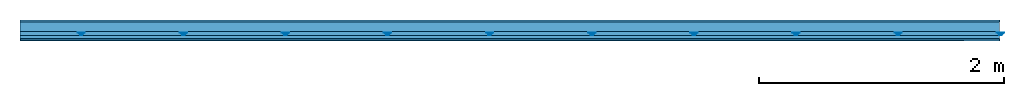
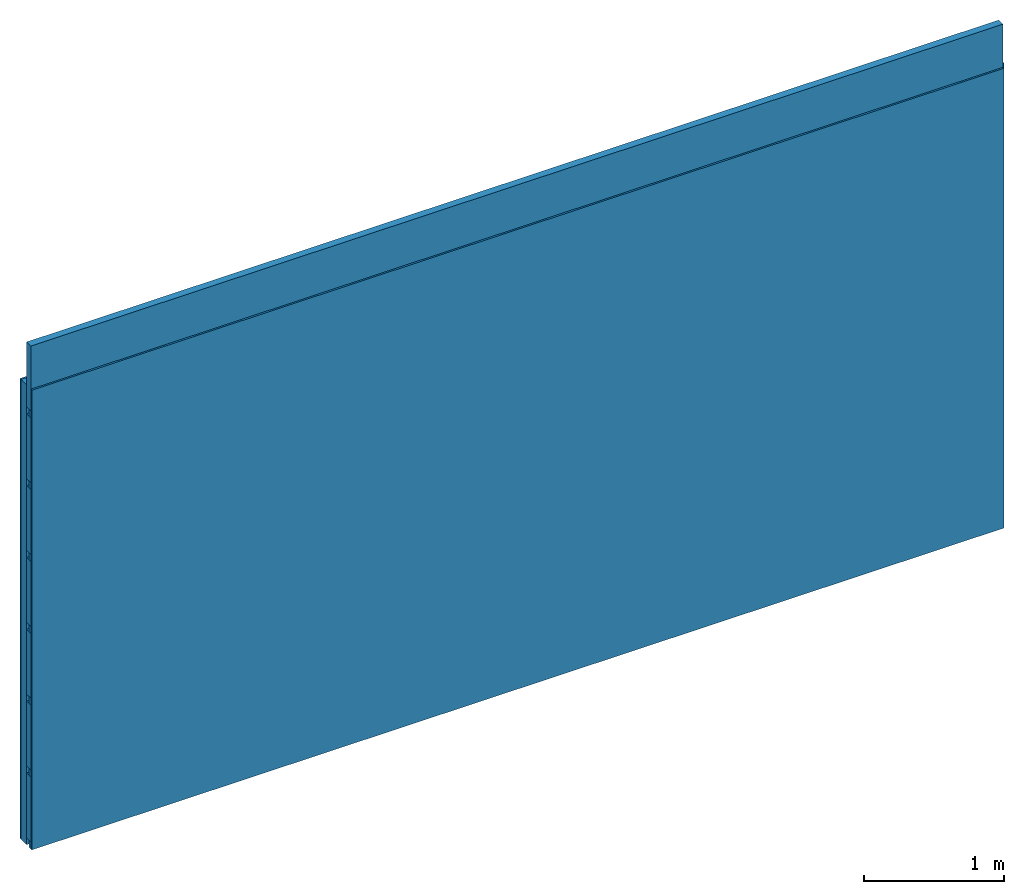
# One storey: 4 members, 2 plates, 1 element without a shape of its own.
"""IFC4 building model written with IfcOpenShell, lengths in metres."""

import ifcopenshell
import ifcopenshell.guid

model = None  # the IFC model being written
_history = None  # IfcOwnerHistory: only IFC2X3 demands one
_inside = {}  # id of a spatial element -> (the spatial element, [elements in it])
_under = {}  # id of a project, library or spatial element -> (it, [spatial elements below it])
_declared = {}  # id of a project -> (the project, [libraries it declares])
_typed = {}  # id of a type object -> (the type object, [elements of that type])
_made_of = {}  # id of a material, layer set ... -> (it, [elements and type objects made of it])


def new_model(schema):
    """Start an empty IFC model of exactly this schema.

    Asked for "IFC4X3", IfcOpenShell would pick the latest addendum, in which some entities
    have other attributes; the version numbers below select the first issue.
    IFC2X3 requires an IfcOwnerHistory on every rooted entity: one is made here for all.
    """
    global model, _history
    if schema == "IFC4X3":
        model = ifcopenshell.file(schema_version=(4, 3, 0, 0))
    else:
        model = ifcopenshell.file(schema=schema)
    _inside.clear()
    _under.clear()
    _declared.clear()
    _typed.clear()
    _made_of.clear()
    _history = None
    if model.schema == "IFC2X3":
        org = make("IfcOrganization", Name="unknown")
        user = make(
            "IfcPersonAndOrganization",
            ThePerson=make("IfcPerson", FamilyName="unknown"),
            TheOrganization=org,
        )
        app = make(
            "IfcApplication",
            ApplicationDeveloper=org,
            Version="unknown",
            ApplicationFullName="unknown",
            ApplicationIdentifier="unknown",
        )
        _history = make(
            "IfcOwnerHistory",
            OwningUser=user,
            OwningApplication=app,
            ChangeAction="ADDED",
            CreationDate=0,
        )
    return model


def make(cls, **values):
    """One entity of the class cls with the attributes given. An attribute that is None is left unset."""
    return model.create_entity(
        cls, **{name: value for name, value in values.items() if value is not None}
    )


def rooted(cls, **values):
    """An entity with a GlobalId (a new one), such as an element, a storey or a relation."""
    return make(cls, GlobalId=ifcopenshell.guid.new(), OwnerHistory=_history, **values)


def si_unit(unit_type, name, prefix=None):
    """IfcSIUnit, for example si_unit("LENGTHUNIT", "METRE", prefix="MILLI")."""
    return make("IfcSIUnit", UnitType=unit_type, Prefix=prefix, Name=name)


def derived_unit(unit_type, elements):
    """IfcDerivedUnit: a product of units, each with its exponent."""
    return make(
        "IfcDerivedUnit",
        Elements=[
            make("IfcDerivedUnitElement", Unit=unit, Exponent=power)
            for unit, power in elements
        ],
        UnitType=unit_type,
    )


def assignment(units):
    """IfcUnitAssignment: the units of a project."""
    return None if units is None else make("IfcUnitAssignment", Units=units)


def point(xyz):
    """IfcCartesianPoint."""
    return None if xyz is None else make("IfcCartesianPoint", Coordinates=xyz)


def direction(xyz):
    """IfcDirection."""
    return None if xyz is None else make("IfcDirection", DirectionRatios=xyz)


def frame(location, z_axis=None, x_axis=None):
    """IfcAxis2Placement3D, a coordinate frame: its origin and axes. An axis left out is left unset."""
    return make(
        "IfcAxis2Placement3D",
        Location=point(location),
        Axis=direction(z_axis),
        RefDirection=direction(x_axis),
    )


def frame_2d(location, x_axis=None):
    """IfcAxis2Placement2D, a coordinate frame in the plane: its origin and x axis."""
    return make(
        "IfcAxis2Placement2D", Location=point(location), RefDirection=direction(x_axis)
    )


def origin():
    """The frame at (0, 0, 0) with its axes left unset."""
    return frame((0.0, 0.0, 0.0))


def origin_with_axes():
    """The frame at (0, 0, 0) with the z axis (0, 0, 1) and the x axis (1, 0, 0) written out."""
    return frame((0.0, 0.0, 0.0), z_axis=(0.0, 0.0, 1.0), x_axis=(1.0, 0.0, 0.0))


def place(relative_to, where):
    """IfcLocalPlacement: puts the frame where relative to a parent placement (None: the world)."""
    return make(
        "IfcLocalPlacement", PlacementRelTo=relative_to, RelativePlacement=where
    )


def context(
    kind, dimensions, precision=None, world=None, true_north=None, identifier=None
):
    """IfcGeometricRepresentationContext, for example the 3D "Model" context."""
    return make(
        "IfcGeometricRepresentationContext",
        ContextIdentifier=identifier,
        ContextType=kind,
        CoordinateSpaceDimension=dimensions,
        Precision=precision,
        WorldCoordinateSystem=world,
        TrueNorth=true_north,
    )


def project(units=None, contexts=None):
    """IfcProject with its units and contexts."""
    return rooted(
        "IfcProject",
        Name="project",
        RepresentationContexts=contexts,
        UnitsInContext=assignment(units),
    )


def spatial(cls, under=None, at=None, **own):
    """A site, building, storey or space (cls), placed at a placement, below another one or the project."""
    s = rooted(cls, ObjectPlacement=at, **own)
    if under is not None:
        _under.setdefault(under.id(), (under, []))[1].append(s)
    return s


def polyline(points):
    """IfcPolyline through the points."""
    return make("IfcPolyline", Points=[point(p) for p in points])


def profile(cls, at=None, kind="AREA", **sizes):
    """A parametric profile (cls). Its sizes go by their IFC names, for example OverallWidth=200.0."""
    return make(cls, ProfileType=kind, Position=at, **sizes)


def rectangle(**sizes):
    """IfcRectangleProfileDef."""
    return profile("IfcRectangleProfileDef", **sizes)


def outline(outer, holes=None, kind="AREA"):
    """IfcArbitraryClosedProfileDef: a profile drawn as a closed curve; with holes, ...WithVoids."""
    if holes is None:
        return make("IfcArbitraryClosedProfileDef", ProfileType=kind, OuterCurve=outer)
    return make(
        "IfcArbitraryProfileDefWithVoids",
        ProfileType=kind,
        OuterCurve=outer,
        InnerCurves=holes,
    )


def extrude(swept, where, along, depth):
    """IfcExtrudedAreaSolid: the profile swept, set in the frame where, extruded along a direction by depth."""
    return make(
        "IfcExtrudedAreaSolid",
        SweptArea=swept,
        Position=where,
        ExtrudedDirection=direction(along),
        Depth=depth,
    )


def shape(context_of_items, identifier, shape_type, items):
    """IfcShapeRepresentation: the items that make up one representation, for example the "Body"."""
    return make(
        "IfcShapeRepresentation",
        ContextOfItems=context_of_items,
        RepresentationIdentifier=identifier,
        RepresentationType=shape_type,
        Items=items,
    )


def material(Name=None, Category=None):
    """IfcMaterial."""
    return make("IfcMaterial", Name=Name, Category=Category)


def layer(
    of_material, thickness, ventilated=None, Name=None, Category=None, Priority=None
):
    """IfcMaterialLayer: one layer of a wall or slab, of a material (None: an air gap)."""
    return make(
        "IfcMaterialLayer",
        Material=of_material,
        LayerThickness=thickness,
        IsVentilated=ventilated,
        Name=Name,
        Category=Category,
        Priority=Priority,
    )


def layer_set(layers, Name=None):
    """IfcMaterialLayerSet."""
    return make("IfcMaterialLayerSet", MaterialLayers=layers, LayerSetName=Name)


def made_of(thing, what):
    """Note that an element or type object is made of a material, layer set ...; save() writes the relation."""
    if what is not None:
        _made_of.setdefault(what.id(), (what, []))[1].append(thing)
    return thing


def type_object(cls, material=None, **own):
    """A type object (cls), such as IfcWallType, which elements share."""
    return made_of(rooted(cls, **own), material)


def element(
    cls,
    number,
    at=None,
    inside=None,
    cuts=None,
    type_object=None,
    material=None,
    context=None,
    identifier="Body",
    shape_type=None,
    held_by="IfcProductDefinitionShape",
    body=None,
    shapes=None,
    **own,
):
    """One element of the class cls, such as IfcWall. Its Tag is "e" and its number.

    at: its placement. inside: the storey or other place that contains it. cuts: it is an
    opening in that element (IfcRelVoidsElement). A single representation is given by context,
    identifier, shape_type and body (its items); several are given by shapes. held_by: the class
    of the entity that holds the representations. save() writes the other relations.
    """
    e = rooted(cls, Tag="e%d" % number, ObjectPlacement=at, **own)
    if body is not None:
        shapes = [shape(context, identifier, shape_type, body)]
    if shapes is not None:
        e.Representation = make(held_by, Representations=shapes)
    if inside is not None:
        _inside.setdefault(inside.id(), (inside, []))[1].append(e)
    if cuts is not None:
        rooted(
            "IfcRelVoidsElement", RelatingBuildingElement=cuts, RelatedOpeningElement=e
        )
    if type_object is not None:
        _typed.setdefault(type_object.id(), (type_object, []))[1].append(e)
    return made_of(e, material)


def aggregate(whole, parts):
    """IfcRelAggregates: a whole, such as a stair, and the parts it consists of."""
    return rooted("IfcRelAggregates", RelatingObject=whole, RelatedObjects=parts)


def save(model, path):
    """Write the relations noted so far, then the file.

    IfcRelAggregates (storeys below a building ...), IfcRelContainedInSpatialStructure (elements
    in a storey), IfcRelDefinesByType, IfcRelAssociatesMaterial and IfcRelDeclares: one each for
    every whole, place, type object, material and project.
    """
    for whole, parts in _under.values():
        aggregate(whole, parts)
    for where, things in _inside.values():
        rooted(
            "IfcRelContainedInSpatialStructure",
            RelatedElements=things,
            RelatingStructure=where,
        )
    for kind, things in _typed.values():
        rooted("IfcRelDefinesByType", RelatedObjects=things, RelatingType=kind)
    for what, things in _made_of.values():
        rooted("IfcRelAssociatesMaterial", RelatedObjects=things, RelatingMaterial=what)
    for by, libraries in _declared.values():
        rooted("IfcRelDeclares", RelatingContext=by, RelatedDefinitions=libraries)
    model.write(path)


model = new_model("IFC4")

# Units and contexts
plan_context = context("Plan", 3, precision=1e-05, world=origin(), true_north=direction((0.0, 1.0)))
model_context = context("Model", 3, precision=1e-05, world=origin(), true_north=direction((0.0, 1.0)))
ifc_project = project(units=[si_unit("LENGTHUNIT", "METRE"), derived_unit("SOUNDPRESSUREUNIT", [(si_unit("PRESSUREUNIT", "PASCAL", prefix="MICRO"), 0)]), si_unit("ENERGYUNIT", "JOULE", prefix="MEGA"), si_unit("MASSUNIT", "GRAM", prefix="KILO"), derived_unit("THERMALTRANSMITTANCEUNIT", [(si_unit("POWERUNIT", "WATT"), 1), (si_unit("AREAUNIT", "SQUARE_METRE"), -1), (si_unit("THERMODYNAMICTEMPERATUREUNIT", "KELVIN"), -1)]), derived_unit("AREADENSITYUNIT", [(si_unit("MASSUNIT", "GRAM", prefix="KILO"), 1), (si_unit("AREAUNIT", "SQUARE_METRE"), -1)]), derived_unit("USERDEFINED", [(si_unit("ENERGYUNIT", "JOULE", prefix="MEGA"), 1), (si_unit("AREAUNIT", "SQUARE_METRE"), -1)])], contexts=[plan_context, model_context])

# Site, building, storey
site = spatial("IfcSite", under=ifc_project)
building_placement = place(None, origin())
building = spatial("IfcBuilding", under=site, at=building_placement)
storey_placement = place(building_placement, origin())
storey = spatial("IfcBuildingStorey", under=building, at=storey_placement)

# Wall, members, plates
ifc_material_1 = material(Name="Glued joints")
ifc_layer_1 = layer(ifc_material_1, 0.0, Name="Surface")
ifc_material_2 = material(Category="03.007")
ifc_layer_2 = layer(ifc_material_2, 0.015, Name="1st layer")
ifc_material_3 = material(Name="of the art")
ifc_layer_3 = layer(ifc_material_3, 0.0, Name="Bond")
ifc_layer_4 = layer(None, 0.08, Name="Support")
ifc_material_4 = material(Name="no composite action")
ifc_layer_5 = layer(ifc_material_4, 0.0, Name="Bond")
ifc_layer_6 = layer(None, 0.03, Name="Coupling")
ifc_layer_7 = layer(None, 0.03, Name="Battens / profiles")
ifc_layer_8 = layer(ifc_material_2, 0.015, Name="Covering 1st layer")
ifc_layer_9 = layer(ifc_material_1, 0.0, Name="Surface")
ifc_layer_set = layer_set([ifc_layer_1, ifc_layer_2, ifc_layer_3, ifc_layer_4, ifc_layer_5, ifc_layer_6, ifc_layer_7, ifc_layer_8, ifc_layer_9])
wall_type = type_object("IfcWallType", Name="C0113", PredefinedType="NOTDEFINED", material=ifc_layer_set)
wall_placement = place(None, frame((0.0, 0.0, 0.0), z_axis=(0.0, -1.0, 0.0), x_axis=(1.0, 0.0, 0.0)))
wall = element("IfcWall", 1, at=wall_placement, inside=storey, type_object=wall_type, material=ifc_layer_set, Name="Wall #1")
ifc_material_5 = material()
member_1_placement = place(wall_placement, origin())
member_1 = element("IfcMember", 2, at=member_1_placement, material=ifc_material_5, Name="Support", context=plan_context, shape_type="SweptSolid", body=[
    extrude(rectangle(XDim=1.0, YDim=0.08, at=frame_2d((0.5, 0.04), x_axis=(1.0, 0.0))), frame((0.0, 4.0, 0.015), z_axis=(0.0, -1.0, 0.0), x_axis=(1.0, 0.0, 0.0)), (0.0, 0.0, 1.0), 4.0),
    extrude(rectangle(XDim=1.0, YDim=0.08, at=frame_2d((0.5, 0.04), x_axis=(1.0, 0.0))), frame((1.0, 4.0, 0.015), z_axis=(0.0, -1.0, 0.0), x_axis=(1.0, 0.0, 0.0)), (0.0, 0.0, 1.0), 4.0),
    extrude(rectangle(XDim=1.0, YDim=0.08, at=frame_2d((0.5, 0.04), x_axis=(1.0, 0.0))), frame((2.0, 4.0, 0.015), z_axis=(0.0, -1.0, 0.0), x_axis=(1.0, 0.0, 0.0)), (0.0, 0.0, 1.0), 4.0),
    extrude(rectangle(XDim=1.0, YDim=0.08, at=frame_2d((0.5, 0.04), x_axis=(1.0, 0.0))), frame((3.0, 4.0, 0.015), z_axis=(0.0, -1.0, 0.0), x_axis=(1.0, 0.0, 0.0)), (0.0, 0.0, 1.0), 4.0),
    extrude(rectangle(XDim=1.0, YDim=0.08, at=frame_2d((0.5, 0.04), x_axis=(1.0, 0.0))), frame((4.0, 4.0, 0.015), z_axis=(0.0, -1.0, 0.0), x_axis=(1.0, 0.0, 0.0)), (0.0, 0.0, 1.0), 4.0),
    extrude(rectangle(XDim=1.0, YDim=0.08, at=frame_2d((0.5, 0.04), x_axis=(1.0, 0.0))), frame((5.0, 4.0, 0.015), z_axis=(0.0, -1.0, 0.0), x_axis=(1.0, 0.0, 0.0)), (0.0, 0.0, 1.0), 4.0),
    extrude(rectangle(XDim=1.0, YDim=0.08, at=frame_2d((0.5, 0.04), x_axis=(1.0, 0.0))), frame((6.0, 4.0, 0.015), z_axis=(0.0, -1.0, 0.0), x_axis=(1.0, 0.0, 0.0)), (0.0, 0.0, 1.0), 4.0),
    extrude(rectangle(XDim=1.0, YDim=0.08, at=frame_2d((0.5, 0.04), x_axis=(1.0, 0.0))), frame((7.0, 4.0, 0.015), z_axis=(0.0, -1.0, 0.0), x_axis=(1.0, 0.0, 0.0)), (0.0, 0.0, 1.0), 4.0),
])
ifc_material_6 = material()
member_2_placement = place(wall_placement, origin())
member_2 = element("IfcMember", 3, at=member_2_placement, material=ifc_material_6, Name="Coupling", context=plan_context, shape_type="SweptSolid", body=[
    extrude(outline(polyline([(0.0, 0.0), (0.06, 0.0), (0.04, 0.02), (0.02, 0.02), (0.0, 0.0)])), frame((0.47, 4.0, 0.105), z_axis=(0.0, -1.0, 0.0), x_axis=(1.0, 0.0, 0.0)), (0.0, 0.0, 1.0), 4.0),
    extrude(outline(polyline([(0.0, 0.0), (0.06, 0.0), (0.04, 0.02), (0.02, 0.02), (0.0, 0.0)])), frame((1.304, 4.0, 0.105), z_axis=(0.0, -1.0, 0.0), x_axis=(1.0, 0.0, 0.0)), (0.0, 0.0, 1.0), 4.0),
    extrude(outline(polyline([(0.0, 0.0), (0.06, 0.0), (0.04, 0.02), (0.02, 0.02), (0.0, 0.0)])), frame((2.138, 4.0, 0.105), z_axis=(0.0, -1.0, 0.0), x_axis=(1.0, 0.0, 0.0)), (0.0, 0.0, 1.0), 4.0),
    extrude(outline(polyline([(0.0, 0.0), (0.06, 0.0), (0.04, 0.02), (0.02, 0.02), (0.0, 0.0)])), frame((2.972, 4.0, 0.105), z_axis=(0.0, -1.0, 0.0), x_axis=(1.0, 0.0, 0.0)), (0.0, 0.0, 1.0), 4.0),
    extrude(outline(polyline([(0.0, 0.0), (0.06, 0.0), (0.04, 0.02), (0.02, 0.02), (0.0, 0.0)])), frame((3.806, 4.0, 0.105), z_axis=(0.0, -1.0, 0.0), x_axis=(1.0, 0.0, 0.0)), (0.0, 0.0, 1.0), 4.0),
    extrude(outline(polyline([(0.0, 0.0), (0.06, 0.0), (0.04, 0.02), (0.02, 0.02), (0.0, 0.0)])), frame((4.64, 4.0, 0.105), z_axis=(0.0, -1.0, 0.0), x_axis=(1.0, 0.0, 0.0)), (0.0, 0.0, 1.0), 4.0),
    extrude(outline(polyline([(0.0, 0.0), (0.06, 0.0), (0.04, 0.02), (0.02, 0.02), (0.0, 0.0)])), frame((5.474, 4.0, 0.105), z_axis=(0.0, -1.0, 0.0), x_axis=(1.0, 0.0, 0.0)), (0.0, 0.0, 1.0), 4.0),
    extrude(outline(polyline([(0.0, 0.0), (0.06, 0.0), (0.04, 0.02), (0.02, 0.02), (0.0, 0.0)])), frame((6.308, 4.0, 0.105), z_axis=(0.0, -1.0, 0.0), x_axis=(1.0, 0.0, 0.0)), (0.0, 0.0, 1.0), 4.0),
    extrude(outline(polyline([(0.0, 0.0), (0.06, 0.0), (0.04, 0.02), (0.02, 0.02), (0.0, 0.0)])), frame((7.142, 4.0, 0.105), z_axis=(0.0, -1.0, 0.0), x_axis=(1.0, 0.0, 0.0)), (0.0, 0.0, 1.0), 4.0),
    extrude(outline(polyline([(0.0, 0.0), (0.06, 0.0), (0.04, 0.02), (0.02, 0.02), (0.0, 0.0)])), frame((7.976, 4.0, 0.105), z_axis=(0.0, -1.0, 0.0), x_axis=(1.0, 0.0, 0.0)), (0.0, 0.0, 1.0), 4.0),
])
member_3_placement = place(wall_placement, origin())
member_3 = element("IfcMember", 4, at=member_3_placement, material=ifc_material_6, Name="Battens / profiles", context=plan_context, shape_type="SweptSolid", body=[
    extrude(rectangle(XDim=0.06, YDim=0.03, at=frame_2d((0.03, 0.015), x_axis=(1.0, 0.0))), frame((0.0, 0.0, 0.125), z_axis=(1.0, 0.0, 0.0), x_axis=(0.0, 1.0, 0.0)), (0.0, 0.0, 1.0), 8.0),
    extrude(rectangle(XDim=0.06, YDim=0.03, at=frame_2d((0.03, 0.015), x_axis=(1.0, 0.0))), frame((0.0, 0.625, 0.125), z_axis=(1.0, 0.0, 0.0), x_axis=(0.0, 1.0, 0.0)), (0.0, 0.0, 1.0), 8.0),
    extrude(rectangle(XDim=0.06, YDim=0.03, at=frame_2d((0.03, 0.015), x_axis=(1.0, 0.0))), frame((0.0, 1.25, 0.125), z_axis=(1.0, 0.0, 0.0), x_axis=(0.0, 1.0, 0.0)), (0.0, 0.0, 1.0), 8.0),
    extrude(rectangle(XDim=0.06, YDim=0.03, at=frame_2d((0.03, 0.015), x_axis=(1.0, 0.0))), frame((0.0, 1.875, 0.125), z_axis=(1.0, 0.0, 0.0), x_axis=(0.0, 1.0, 0.0)), (0.0, 0.0, 1.0), 8.0),
    extrude(rectangle(XDim=0.06, YDim=0.03, at=frame_2d((0.03, 0.015), x_axis=(1.0, 0.0))), frame((0.0, 2.5, 0.125), z_axis=(1.0, 0.0, 0.0), x_axis=(0.0, 1.0, 0.0)), (0.0, 0.0, 1.0), 8.0),
    extrude(rectangle(XDim=0.06, YDim=0.03, at=frame_2d((0.03, 0.015), x_axis=(1.0, 0.0))), frame((0.0, 3.125, 0.125), z_axis=(1.0, 0.0, 0.0), x_axis=(0.0, 1.0, 0.0)), (0.0, 0.0, 1.0), 8.0),
    extrude(rectangle(XDim=0.06, YDim=0.03, at=frame_2d((0.03, 0.015), x_axis=(1.0, 0.0))), frame((0.0, 3.75, 0.125), z_axis=(1.0, 0.0, 0.0), x_axis=(0.0, 1.0, 0.0)), (0.0, 0.0, 1.0), 8.0),
])
ifc_material_7 = material()
member_4_placement = place(wall_placement, origin())
member_4 = element("IfcMember", 5, at=member_4_placement, material=ifc_material_7, Name="Cavity", context=plan_context, shape_type="SweptSolid", body=[
    extrude(rectangle(XDim=0.565, YDim=0.06, at=frame_2d((0.2825, 0.03), x_axis=(1.0, 0.0))), frame((0.0, 0.06, 0.095), z_axis=(1.0, 0.0, 0.0), x_axis=(0.0, 1.0, 0.0)), (0.0, 0.0, 1.0), 8.0),
    extrude(rectangle(XDim=0.565, YDim=0.06, at=frame_2d((0.2825, 0.03), x_axis=(1.0, 0.0))), frame((0.0, 0.685, 0.095), z_axis=(1.0, 0.0, 0.0), x_axis=(0.0, 1.0, 0.0)), (0.0, 0.0, 1.0), 8.0),
    extrude(rectangle(XDim=0.565, YDim=0.06, at=frame_2d((0.2825, 0.03), x_axis=(1.0, 0.0))), frame((0.0, 1.31, 0.095), z_axis=(1.0, 0.0, 0.0), x_axis=(0.0, 1.0, 0.0)), (0.0, 0.0, 1.0), 8.0),
    extrude(rectangle(XDim=0.565, YDim=0.06, at=frame_2d((0.2825, 0.03), x_axis=(1.0, 0.0))), frame((0.0, 1.935, 0.095), z_axis=(1.0, 0.0, 0.0), x_axis=(0.0, 1.0, 0.0)), (0.0, 0.0, 1.0), 8.0),
    extrude(rectangle(XDim=0.565, YDim=0.06, at=frame_2d((0.2825, 0.03), x_axis=(1.0, 0.0))), frame((0.0, 2.56, 0.095), z_axis=(1.0, 0.0, 0.0), x_axis=(0.0, 1.0, 0.0)), (0.0, 0.0, 1.0), 8.0),
    extrude(rectangle(XDim=0.565, YDim=0.06, at=frame_2d((0.2825, 0.03), x_axis=(1.0, 0.0))), frame((0.0, 3.185, 0.095), z_axis=(1.0, 0.0, 0.0), x_axis=(0.0, 1.0, 0.0)), (0.0, 0.0, 1.0), 8.0),
    extrude(rectangle(XDim=0.565, YDim=0.06, at=frame_2d((0.2825, 0.03), x_axis=(1.0, 0.0))), frame((0.0, 3.81, 0.095), z_axis=(1.0, 0.0, 0.0), x_axis=(0.0, 1.0, 0.0)), (0.0, 0.0, 1.0), 8.0),
])
plate_1_placement = place(wall_placement, origin())
plate_1 = element("IfcPlate", 6, at=plate_1_placement, material=ifc_material_2, Name="1st layer", context=plan_context, shape_type="SweptSolid", body=[
    extrude(rectangle(XDim=8.0, YDim=4.0, at=frame_2d((4.0, 2.0), x_axis=(1.0, 0.0))), origin_with_axes(), (0.0, 0.0, 1.0), 0.015),
])
plate_2_placement = place(wall_placement, origin())
plate_2 = element("IfcPlate", 7, at=plate_2_placement, material=ifc_material_2, Name="Covering 1st layer", context=plan_context, shape_type="SweptSolid", body=[
    extrude(rectangle(XDim=8.0, YDim=4.0, at=frame_2d((4.0, 2.0), x_axis=(1.0, 0.0))), frame((0.0, 0.0, 0.155), z_axis=(0.0, 0.0, 1.0), x_axis=(1.0, 0.0, 0.0)), (0.0, 0.0, 1.0), 0.015),
])
aggregate(wall, [plate_1, member_1, member_2, member_3, member_4, plate_2])

save(model, "model.ifc")
